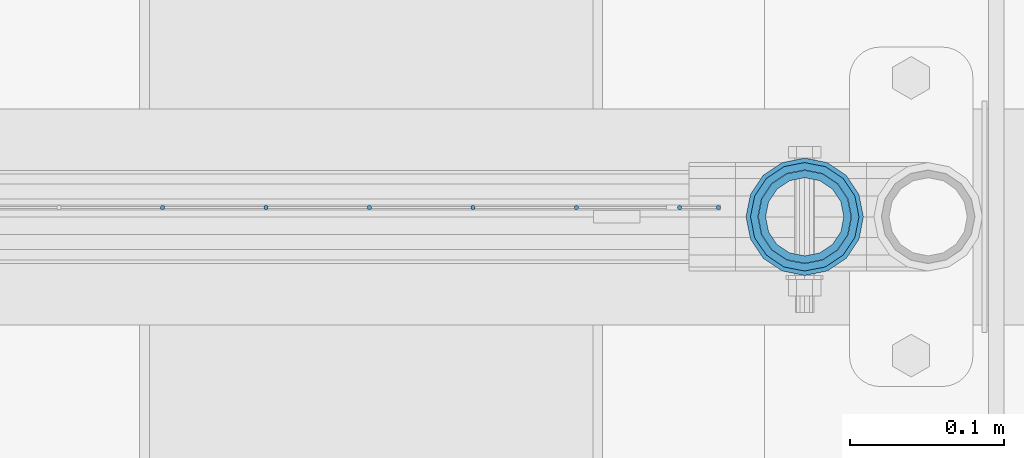
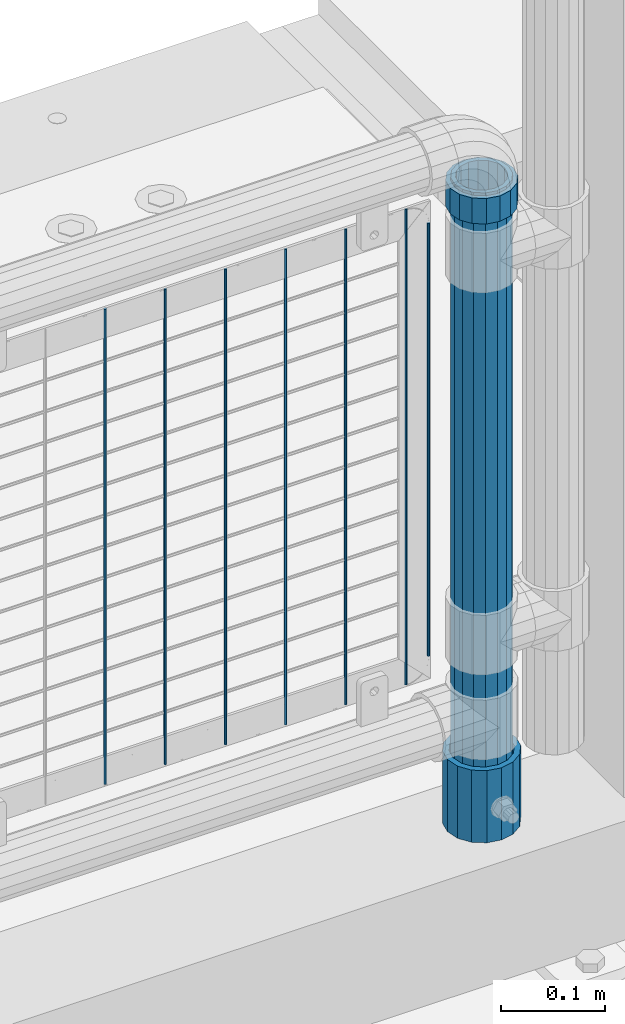
# One storey, part 97 of 240: 10 columns.
"""IFC2X3 building model written with IfcOpenShell, lengths in millimetres."""

from ifc_helpers import new_model, si_unit, frame, origin_with_axes, place, context, subcontext, project, spatial, faceted_brep, material, type_object, element, save


model = new_model("IFC2X3")

# Units and contexts
model_context = context("Model", 3, precision=1e-05, world=origin_with_axes())
body_context = subcontext(model_context, "Body", "Model", "MODEL_VIEW")
ifc_project = project(units=[si_unit("LENGTHUNIT", "METRE", prefix="MILLI"), si_unit("AREAUNIT", "SQUARE_METRE"), si_unit("VOLUMEUNIT", "CUBIC_METRE"), si_unit("MASSUNIT", "GRAM", prefix="KILO"), si_unit("TIMEUNIT", "SECOND"), si_unit("PLANEANGLEUNIT", "RADIAN"), si_unit("SOLIDANGLEUNIT", "STERADIAN"), si_unit("THERMODYNAMICTEMPERATUREUNIT", "DEGREE_CELSIUS"), si_unit("LUMINOUSINTENSITYUNIT", "LUMEN")], contexts=[model_context])

# Site, building, storey
site_placement = place(None, origin_with_axes())
site = spatial("IfcSite", under=ifc_project, at=site_placement, CompositionType="ELEMENT")
building_placement = place(site_placement, origin_with_axes())
building = spatial("IfcBuilding", under=site, at=building_placement, Name="Standard", CompositionType="ELEMENT")
storey_placement = place(building_placement, origin_with_axes())
storey = spatial("IfcBuildingStorey", under=building, at=storey_placement, Name="Undefined", CompositionType="ELEMENT", Elevation=0.0)

# Columns
ifc_material_1 = material(Name="Misc_Undefined")
column_type_1 = type_object("IfcColumnType", PredefinedType="NOTDEFINED")
column_1_placement = place(storey_placement, frame((55881.0, 34664.5, 894.85), z_axis=(1.0, 0.0, 0.0), x_axis=(0.0, 0.0, 1.0)))
element("IfcColumn", 1, at=column_1_placement, inside=storey, type_object=column_type_1, material=ifc_material_1, context=body_context, shape_type="Brep", body=[
    faceted_brep([(0.0, -30.3499999999985, 0.0), (0.0, -28.0397438117143, 11.6144421722784), (30.0, -28.0397438117143, 11.6144421722805), (30.0, -30.3499999999985, 0.0), (0.0, -21.4606908090136, 21.4606908090136), (30.0, -21.4606908090136, 21.4606908090117), (0.0, -11.6144421722784, 28.0397438117143), (30.0, -11.6144421722784, 28.0397438117176), (0.0, 0.0, 30.3499999999985), (30.0, 0.0, 30.35), (0.0, 11.6144421722784, 28.0397438117143), (30.0, 11.6144421722784, 28.0397438117176), (0.0, 21.4606908090136, 21.4606908090136), (30.0, 21.4606908090136, 21.4606908090117), (0.0, 28.0397438117143, 11.6144421722784), (30.0, 28.0397438117143, 11.6144421722805), (0.0, 30.3499999999985, 0.0), (30.0, 30.3499999999985, 0.0), (0.0, 28.0397438117143, -11.6144421722784), (30.0, 28.0397438117143, -11.6144421722805), (0.0, 21.4606908090136, -21.4606908090136), (30.0, 21.4606908090136, -21.4606908090117), (0.0, 11.6144421722784, -28.0397438117143), (30.0, 11.6144421722784, -28.0397438117176), (0.0, 0.0, -30.3499999999985), (30.0, 0.0, -30.35), (0.0, -11.6144421722784, -28.0397438117143), (30.0, -11.6144421722784, -28.0397438117176), (0.0, -21.4606908090136, -21.4606908090136), (30.0, -21.4606908090136, -21.4606908090117), (0.0, -28.0397438117143, -11.6144421722784), (30.0, -28.0397438117143, -11.6144421722805), (0.0, -35.1500000000015, 0.0), (0.0, -32.4743655677739, -13.4513226476338), (30.0, -32.4743655677739, -13.4513226476329), (30.0, -35.1500000000015, 0.0), (0.0, -24.8548033587067, -24.8548033587067), (30.0, -24.8548033587067, -24.8548033587072), (0.0, -13.4513226476338, -32.4743655677739), (30.0, -13.4513226476338, -32.4743655677718), (0.0, 0.0, -35.1500000000015), (30.0, 0.0, -35.15), (0.0, 13.4513226476338, -32.4743655677739), (30.0, 13.4513226476338, -32.4743655677718), (0.0, 24.8548033587067, -24.8548033587067), (30.0, 24.8548033587067, -24.8548033587072), (0.0, 32.4743655677739, -13.4513226476338), (30.0, 32.4743655677739, -13.4513226476329), (0.0, 35.1500000000015, 0.0), (30.0, 35.1500000000015, 0.0), (0.0, 32.4743655677739, 13.4513226476338), (30.0, 32.4743655677739, 13.4513226476329), (0.0, 24.8548033587067, 24.8548033587067), (30.0, 24.8548033587067, 24.8548033587072), (0.0, 13.4513226476338, 32.4743655677739), (30.0, 13.4513226476338, 32.4743655677718), (0.0, 0.0, 35.1500000000015), (30.0, 0.0, 35.15), (0.0, -13.4513226476338, 32.4743655677739), (30.0, -13.4513226476338, 32.4743655677718), (0.0, -24.8548033587067, 24.8548033587067), (30.0, -24.8548033587067, 24.8548033587072), (0.0, -32.4743655677739, 13.4513226476338), (30.0, -32.4743655677739, 13.4513226476329)], [[[0, 1, 2, 3]], [[1, 4, 5, 2]], [[4, 6, 7, 5]], [[6, 8, 9, 7]], [[8, 10, 11, 9]], [[10, 12, 13, 11]], [[12, 14, 15, 13]], [[14, 16, 17, 15]], [[16, 18, 19, 17]], [[18, 20, 21, 19]], [[20, 22, 23, 21]], [[22, 24, 25, 23]], [[24, 26, 27, 25]], [[26, 28, 29, 27]], [[28, 30, 31, 29]], [[30, 0, 3, 31]], [[32, 33, 34, 35]], [[33, 36, 37, 34]], [[36, 38, 39, 37]], [[38, 40, 41, 39]], [[40, 42, 43, 41]], [[42, 44, 45, 43]], [[44, 46, 47, 45]], [[46, 48, 49, 47]], [[48, 50, 51, 49]], [[50, 52, 53, 51]], [[52, 54, 55, 53]], [[54, 56, 57, 55]], [[56, 58, 59, 57]], [[58, 60, 61, 59]], [[60, 62, 63, 61]], [[62, 32, 35, 63]], [[37, 39, 41, 43, 45, 47, 49, 51, 53, 55, 57, 59, 61, 63, 35, 34], [5, 7, 9, 11, 13, 15, 17, 19, 21, 23, 25, 27, 29, 31, 3, 2]], [[62, 60, 58, 56, 54, 52, 50, 48, 46, 44, 42, 40, 38, 36, 33, 32], [30, 28, 26, 24, 22, 20, 18, 16, 14, 12, 10, 8, 6, 4, 1, 0]]]),
])
ifc_material_2 = material()
column_type_2 = type_object("IfcColumnType", PredefinedType="NOTDEFINED")
column_2_placement = place(storey_placement, frame((55881.0, 34664.5, 168.019999999998), z_axis=(-1.0, 0.0, 0.0), x_axis=(0.0, 0.0, 1.0)))
element("IfcColumn", 2, at=column_2_placement, inside=storey, type_object=column_type_2, material=ifc_material_2, context=body_context, shape_type="Brep", body=[
    faceted_brep([(0.0, -25.3499999999985, 0.0), (0.0, -23.4203461491634, 9.70102501045767), (760.0, -23.4203461491634, 9.70102501045767), (760.0, -25.3499999999985, 0.0), (0.0, -17.9251569030821, 17.9251569030821), (760.0, -17.9251569030821, 17.9251569030821), (0.0, -9.70102501045767, 23.4203461491634), (760.0, -9.70102501045767, 23.4203461491634), (0.0, 0.0, 25.3499999999985), (760.0, 0.0, 25.3499999999985), (0.0, 9.70102501045767, 23.4203461491634), (760.0, 9.70102501045767, 23.4203461491634), (0.0, 17.9251569030821, 17.9251569030821), (760.0, 17.9251569030821, 17.9251569030821), (0.0, 23.4203461491634, 9.70102501045767), (760.0, 23.4203461491634, 9.70102501045767), (0.0, 25.3499999999985, 0.0), (760.0, 25.3499999999985, 0.0), (0.0, 23.4203461491634, -9.70102501045767), (760.0, 23.4203461491634, -9.70102501045767), (0.0, 17.9251569030821, -17.9251569030821), (760.0, 17.9251569030821, -17.9251569030821), (0.0, 9.70102501045767, -23.4203461491634), (760.0, 9.70102501045767, -23.4203461491634), (0.0, 0.0, -25.3499999999985), (760.0, 0.0, -25.3499999999985), (0.0, -9.70102501045767, -23.4203461491634), (760.0, -9.70102501045767, -23.4203461491634), (0.0, -17.9251569030821, -17.9251569030821), (760.0, -17.9251569030821, -17.9251569030821), (0.0, -23.4203461491634, -9.70102501045767), (760.0, -23.4203461491634, -9.70102501045767), (0.0, -30.1500000000015, 0.0), (0.0, -27.8549679052157, -11.5379054858058), (760.0, -27.8549679052157, -11.5379054858058), (760.0, -30.1500000000015, 0.0), (0.0, -21.3192694527752, -21.3192694527752), (760.0, -21.3192694527752, -21.3192694527752), (0.0, -11.5379054858058, -27.8549679052157), (760.0, -11.5379054858058, -27.8549679052157), (0.0, 0.0, -30.1500000000015), (760.0, 0.0, -30.1500000000015), (0.0, 11.5379054858058, -27.8549679052157), (760.0, 11.5379054858058, -27.8549679052157), (0.0, 21.3192694527752, -21.3192694527752), (760.0, 21.3192694527752, -21.3192694527752), (0.0, 27.8549679052157, -11.5379054858058), (760.0, 27.8549679052157, -11.5379054858058), (0.0, 30.1500000000015, 0.0), (760.0, 30.1500000000015, 0.0), (0.0, 27.8549679052157, 11.5379054858058), (760.0, 27.8549679052157, 11.5379054858058), (0.0, 21.3192694527752, 21.3192694527752), (760.0, 21.3192694527752, 21.3192694527752), (0.0, 11.5379054858058, 27.8549679052157), (760.0, 11.5379054858058, 27.8549679052157), (0.0, 0.0, 30.1500000000015), (760.0, 0.0, 30.1500000000015), (0.0, -11.5379054858058, 27.8549679052157), (760.0, -11.5379054858058, 27.8549679052157), (0.0, -21.3192694527752, 21.3192694527752), (760.0, -21.3192694527752, 21.3192694527752), (0.0, -27.8549679052157, 11.5379054858058), (760.0, -27.8549679052157, 11.5379054858058)], [[[0, 1, 2, 3]], [[1, 4, 5, 2]], [[4, 6, 7, 5]], [[6, 8, 9, 7]], [[8, 10, 11, 9]], [[10, 12, 13, 11]], [[12, 14, 15, 13]], [[14, 16, 17, 15]], [[16, 18, 19, 17]], [[18, 20, 21, 19]], [[20, 22, 23, 21]], [[22, 24, 25, 23]], [[24, 26, 27, 25]], [[26, 28, 29, 27]], [[28, 30, 31, 29]], [[30, 0, 3, 31]], [[32, 33, 34, 35]], [[33, 36, 37, 34]], [[36, 38, 39, 37]], [[38, 40, 41, 39]], [[40, 42, 43, 41]], [[42, 44, 45, 43]], [[44, 46, 47, 45]], [[46, 48, 49, 47]], [[48, 50, 51, 49]], [[50, 52, 53, 51]], [[52, 54, 55, 53]], [[54, 56, 57, 55]], [[56, 58, 59, 57]], [[58, 60, 61, 59]], [[60, 62, 63, 61]], [[62, 32, 35, 63]], [[37, 39, 41, 43, 45, 47, 49, 51, 53, 55, 57, 59, 61, 63, 35, 34], [5, 7, 9, 11, 13, 15, 17, 19, 21, 23, 25, 27, 29, 31, 3, 2]], [[62, 60, 58, 56, 54, 52, 50, 48, 46, 44, 42, 40, 38, 36, 33, 32], [30, 28, 26, 24, 22, 20, 18, 16, 14, 12, 10, 8, 6, 4, 1, 0]]]),
])
column_type_3 = type_object("IfcColumnType", Name="D3", PredefinedType="NOTDEFINED")
for number, where, z_axis, x_axis in (
    (3, (55800.0020000002, 34670.4997841009, 353.02), (-1.0, 0.0, 0.0), (0.0, 0.0, 1.0)),
    (4, (55732.9740000002, 34670.4997983097, 353.02), (-1.0, 0.0, 0.0), (0.0, 0.0, 1.0)),
    (5, (55665.9460000002, 34670.4998125185, 353.02), (-1.0, 0.0, 0.0), (0.0, 0.0, 1.0)),
    (6, (55598.9180000002, 34670.4998267273, 353.02), (-1.0, 0.0, 0.0), (0.0, 0.0, 1.0)),
    (7, (55531.8900000001, 34670.4998409362, 353.02), (-1.0, 0.0, 0.0), (0.0, 0.0, 1.0)),
    (8, (55464.8620000001, 34670.499855145, 353.02), (-1.0, 0.0, 0.0), (0.0, 0.0, 1.0)),
):
    element("IfcColumn", number, at=place(storey_placement, frame(where, z_axis=z_axis, x_axis=x_axis)), inside=storey, type_object=column_type_3, material=ifc_material_1, ObjectType="D3", context=body_context, shape_type="Brep", body=[
        faceted_brep([(-7.27595761418343e-12, -1.49999999999272, 0.0), (-7.27595761418343e-12, -0.749999999992724, -1.29903810567669), (560.0, -0.75, -1.29903810567339), (560.0, -1.5, 0.0), (0.0, 0.750000000007276, -1.29903810567669), (560.0, 0.75, -1.29903810567339), (0.0, 1.50000000000728, 0.0), (560.0, 1.5, 0.0), (0.0, 0.750000000007276, 1.29903810567669), (560.0, 0.75, 1.29903810567339), (-7.27595761418343e-12, -0.749999999992724, 1.29903810567669), (560.0, -0.75, 1.29903810567339)], [[[0, 1, 2, 3]], [[1, 4, 5, 2]], [[4, 6, 7, 5]], [[6, 8, 9, 7]], [[8, 10, 11, 9]], [[10, 0, 3, 11]], [[5, 7, 9, 11, 3, 2]], [[10, 8, 6, 4, 1, 0]]]),
    ])
column_3_placement = place(storey_placement, frame((55825.0000000001, 34670.4997788013, 378.02), z_axis=(-1.0, 0.0, 0.0), x_axis=(0.0, 0.0, 1.0)))
element("IfcColumn", 9, at=column_3_placement, inside=storey, type_object=column_type_3, material=ifc_material_1, ObjectType="D3", context=body_context, shape_type="Brep", body=[
    faceted_brep([(-7.27595761418343e-12, -1.49999999999272, 0.0), (-7.27595761418343e-12, -0.749999999992724, -1.29903810567669), (510.0, -0.75, -1.29903810567339), (510.0, -1.5, 0.0), (0.0, 0.750000000007276, -1.29903810567669), (510.0, 0.75, -1.29903810567339), (0.0, 1.50000000000728, 0.0), (510.0, 1.5, 0.0), (0.0, 0.750000000007276, 1.29903810567669), (510.0, 0.75, 1.29903810567339), (-7.27595761418343e-12, -0.749999999992724, 1.29903810567669), (510.0, -0.75, 1.29903810567339)], [[[0, 1, 2, 3]], [[1, 4, 5, 2]], [[4, 6, 7, 5]], [[6, 8, 9, 7]], [[8, 10, 11, 9]], [[10, 0, 3, 11]], [[5, 7, 9, 11, 3, 2]], [[10, 8, 6, 4, 1, 0]]]),
])
column_type_4 = type_object("IfcColumnType", PredefinedType="NOTDEFINED")
column_4_placement = place(storey_placement, frame((55881.0, 34664.5, 168.019999999998), z_axis=(0.0, 1.0, 0.0), x_axis=(0.0, 0.0, 1.0)))
element("IfcColumn", 10, at=column_4_placement, inside=storey, type_object=column_type_4, material=ifc_material_2, context=body_context, shape_type="Brep", body=[
    faceted_brep([(0.0, -31.75, 0.0), (0.0, -29.3331751572332, 12.1501989775934), (85.0, -29.3331751572332, 12.1501989775934), (85.0, -31.75, 0.0), (0.0, -22.4506403026753, 22.4506403026753), (85.0, -22.4506403026753, 22.4506403026753), (0.0, -12.1501989775934, 29.3331751572332), (85.0, -12.1501989775934, 29.3331751572332), (0.0, 0.0, 31.75), (85.0, 0.0, 31.75), (0.0, 12.1501989775934, 29.3331751572332), (85.0, 12.1501989775934, 29.3331751572332), (0.0, 22.4506403026753, 22.4506403026753), (85.0, 22.4506403026753, 22.4506403026753), (0.0, 29.3331751572332, 12.1501989775934), (85.0, 29.3331751572332, 12.1501989775934), (0.0, 31.75, 0.0), (85.0, 31.75, 0.0), (0.0, 29.3331751572332, -12.1501989775934), (85.0, 29.3331751572332, -12.1501989775934), (0.0, 22.4506403026753, -22.4506403026753), (85.0, 22.4506403026753, -22.4506403026753), (0.0, 12.1501989775934, -29.3331751572332), (85.0, 12.1501989775934, -29.3331751572332), (0.0, 0.0, -31.75), (85.0, 0.0, -31.75), (0.0, -12.1501989775934, -29.3331751572332), (85.0, -12.1501989775934, -29.3331751572332), (0.0, -22.4506403026753, -22.4506403026753), (85.0, -22.4506403026753, -22.4506403026753), (0.0, -29.3331751572332, -12.1501989775934), (85.0, -29.3331751572332, -12.1501989775934), (0.0, -38.0500000000029, 0.0), (0.0, -35.1536162120537, -14.5611046014892), (85.0, -35.1536162120537, -14.5611046014892), (85.0, -38.0500000000029, 0.0), (0.0, -26.9054130241493, -26.9054130241493), (85.0, -26.9054130241493, -26.9054130241493), (0.0, -14.5611046014892, -35.1536162120537), (85.0, -14.5611046014892, -35.1536162120537), (0.0, 0.0, -38.0500000000029), (85.0, 0.0, -38.0500000000029), (0.0, 14.5611046014892, -35.1536162120537), (85.0, 14.5611046014892, -35.1536162120537), (0.0, 26.9054130241493, -26.9054130241493), (85.0, 26.9054130241493, -26.9054130241493), (0.0, 35.1536162120537, -14.5611046014892), (85.0, 35.1536162120537, -14.5611046014892), (0.0, 38.0500000000029, 0.0), (85.0, 38.0500000000029, 0.0), (0.0, 35.1536162120537, 14.5611046014892), (85.0, 35.1536162120537, 14.5611046014892), (0.0, 26.9054130241493, 26.9054130241493), (85.0, 26.9054130241493, 26.9054130241493), (0.0, 14.5611046014892, 35.1536162120537), (85.0, 14.5611046014892, 35.1536162120537), (0.0, 0.0, 38.0500000000029), (85.0, 0.0, 38.0500000000029), (0.0, -14.5611046014892, 35.1536162120537), (85.0, -14.5611046014892, 35.1536162120537), (0.0, -26.9054130241493, 26.9054130241493), (85.0, -26.9054130241493, 26.9054130241493), (0.0, -35.1536162120537, 14.5611046014892), (85.0, -35.1536162120537, 14.5611046014892)], [[[0, 1, 2, 3]], [[1, 4, 5, 2]], [[4, 6, 7, 5]], [[6, 8, 9, 7]], [[8, 10, 11, 9]], [[10, 12, 13, 11]], [[12, 14, 15, 13]], [[14, 16, 17, 15]], [[16, 18, 19, 17]], [[18, 20, 21, 19]], [[20, 22, 23, 21]], [[22, 24, 25, 23]], [[24, 26, 27, 25]], [[26, 28, 29, 27]], [[28, 30, 31, 29]], [[30, 0, 3, 31]], [[32, 33, 34, 35]], [[33, 36, 37, 34]], [[36, 38, 39, 37]], [[38, 40, 41, 39]], [[40, 42, 43, 41]], [[42, 44, 45, 43]], [[44, 46, 47, 45]], [[46, 48, 49, 47]], [[48, 50, 51, 49]], [[50, 52, 53, 51]], [[52, 54, 55, 53]], [[54, 56, 57, 55]], [[56, 58, 59, 57]], [[58, 60, 61, 59]], [[60, 62, 63, 61]], [[62, 32, 35, 63]], [[37, 39, 41, 43, 45, 47, 49, 51, 53, 55, 57, 59, 61, 63, 35, 34], [5, 7, 9, 11, 13, 15, 17, 19, 21, 23, 25, 27, 29, 31, 3, 2]], [[62, 60, 58, 56, 54, 52, 50, 48, 46, 44, 42, 40, 38, 36, 33, 32], [30, 28, 26, 24, 22, 20, 18, 16, 14, 12, 10, 8, 6, 4, 1, 0]]]),
])

save(model, "model.ifc")
